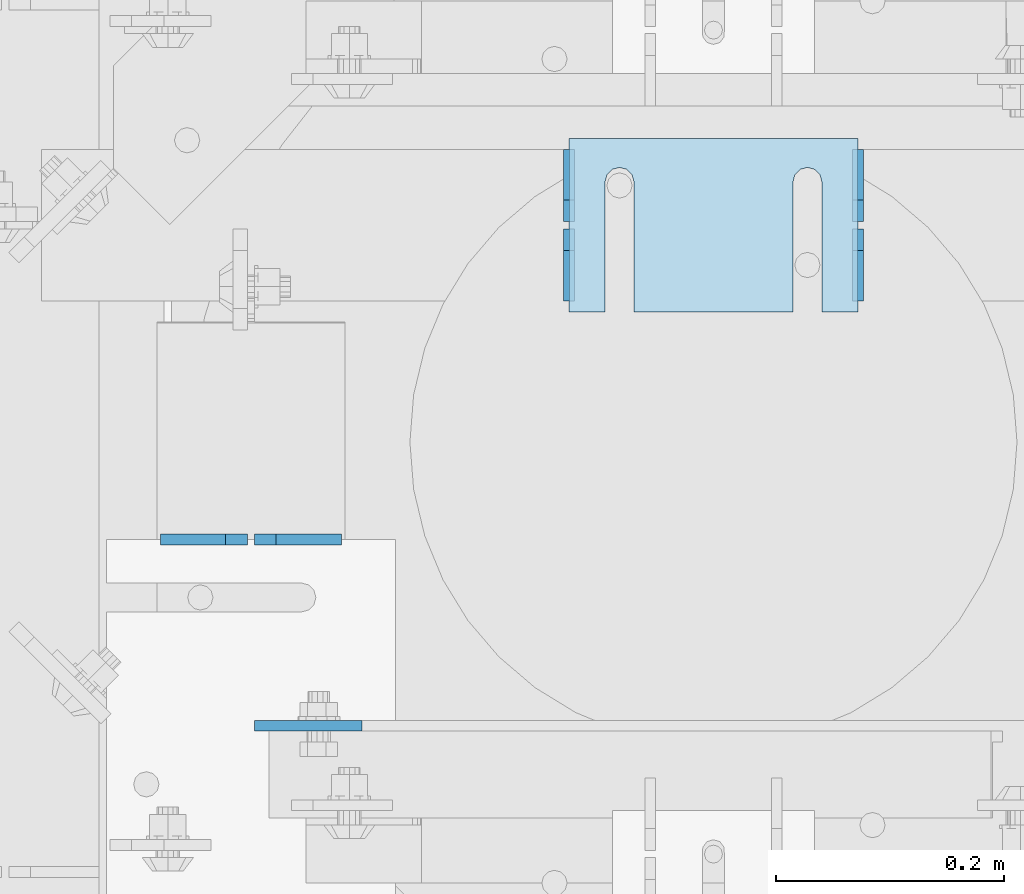
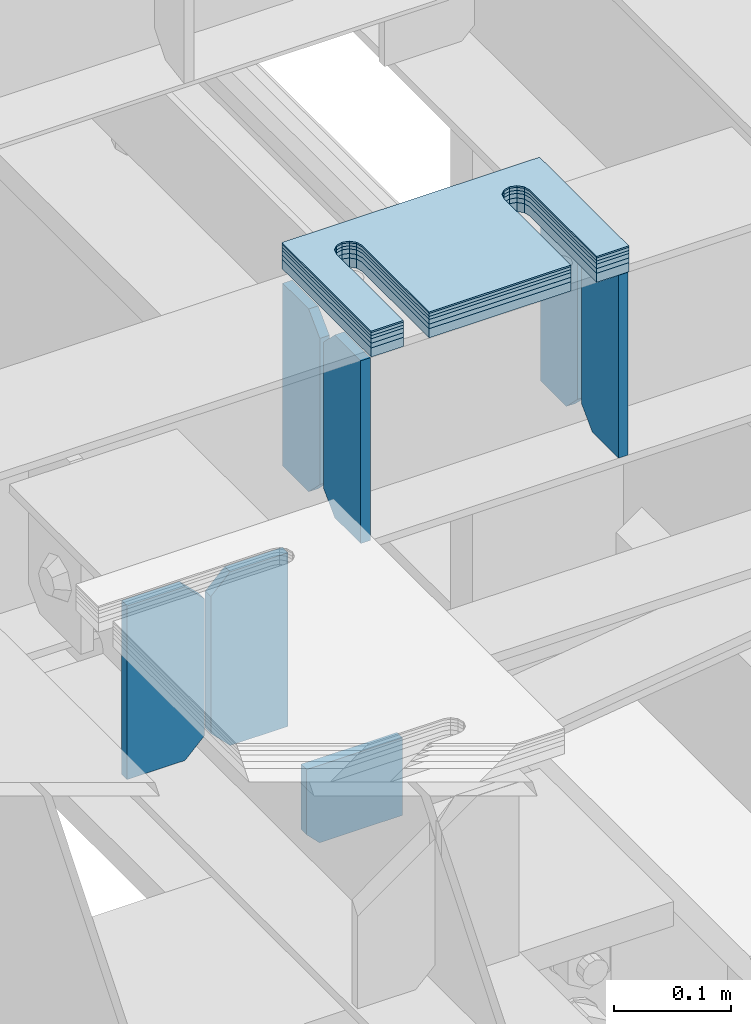
# One storey, part 1635 of 1876: 13 plates, 8 elements without a shape of their own.
"""IFC2X3 building model written with IfcOpenShell, lengths in millimetres."""

from ifc_helpers import new_model, si_unit, frame, origin_with_axes, place, context, subcontext, project, spatial, faceted_brep, material, type_object, element, aggregate, save


model = new_model("IFC2X3")

# Units and contexts
model_context = context("Model", 3, precision=1e-05, world=origin_with_axes())
body_context = subcontext(model_context, "Body", "Model", "MODEL_VIEW")
ifc_project = project(units=[si_unit("LENGTHUNIT", "METRE", prefix="MILLI"), si_unit("AREAUNIT", "SQUARE_METRE"), si_unit("VOLUMEUNIT", "CUBIC_METRE"), si_unit("MASSUNIT", "GRAM", prefix="KILO"), si_unit("TIMEUNIT", "SECOND"), si_unit("PLANEANGLEUNIT", "RADIAN"), si_unit("SOLIDANGLEUNIT", "STERADIAN"), si_unit("THERMODYNAMICTEMPERATUREUNIT", "DEGREE_CELSIUS"), si_unit("LUMINOUSINTENSITYUNIT", "LUMEN")], contexts=[model_context])

# Site, building, storey
site_placement = place(None, origin_with_axes())
site = spatial("IfcSite", under=ifc_project, at=site_placement, CompositionType="ELEMENT")
building_placement = place(site_placement, origin_with_axes())
building = spatial("IfcBuilding", under=site, at=building_placement, Name="Undefined", CompositionType="ELEMENT")
storey_placement = place(building_placement, origin_with_axes())
storey = spatial("IfcBuildingStorey", under=building, at=storey_placement, Name="Undefined", CompositionType="ELEMENT", Elevation=0.0)

# Assembly, plates
assembly_1_placement = place(storey_placement, origin_with_axes())
assembly_1 = element("IfcElementAssembly", 1, at=assembly_1_placement, inside=storey, Name="BEAM", AssemblyPlace="NOTDEFINED", PredefinedType="RIGID_FRAME")
ifc_material = material(Name="STEEL/A36")
plate_type_1 = type_object("IfcPlateType", PredefinedType="NOTDEFINED")
plate_1_placement = place(assembly_1_placement, frame((4092.57517785198, 2355.85161899327, 17792.7000000301), z_axis=(0.0, 0.0, 1.0), x_axis=(-1.0, 0.0, 0.0)))
plate_1 = element("IfcPlate", 2, at=plate_1_placement, type_object=plate_type_1, material=ifc_material, Name="PLATE", context=body_context, shape_type="Brep", body=[
    faceted_brep([(0.0, -4.76249999999982, 0.0), (0.0, -4.76249999999982, 180.975006103516), (0.0, 4.76249999999982, 180.975006103516), (0.0, 4.76249999999982, 0.0), (57.1499977111816, -4.76249999999982, 180.975006103516), (57.1499977111816, 4.76249999999982, 180.975006103516), (76.1999969482422, -4.76249999999982, 161.925006866455), (76.1999969482422, 4.76249999999982, 161.925006866455), (76.1999969482422, -4.76249999999982, 19.0499992370605), (76.1999969482422, 4.76249999999982, 19.0499992370605), (57.1499977111816, -4.76249999999982, 0.0), (57.1499977111816, 4.76249999999982, 0.0)], [[[0, 1, 2, 3]], [[1, 4, 5, 2]], [[4, 6, 7, 5]], [[6, 8, 9, 7]], [[8, 10, 11, 9]], [[10, 0, 3, 11]], [[5, 7, 9, 11, 3, 2]], [[10, 8, 6, 4, 1, 0]]]),
])
plate_2_placement = place(assembly_1_placement, frame((4010.02517785198, 2355.85161899327, 17792.7), z_axis=(0.0, 0.0, 1.0), x_axis=(-1.0, 0.0, 0.0)))
plate_2 = element("IfcPlate", 3, at=plate_2_placement, type_object=plate_type_1, material=ifc_material, Name="PLATE", context=body_context, shape_type="Brep", body=[
    faceted_brep([(0.0, -4.76249999999982, 19.0499992370605), (0.0, -4.76249999999982, 161.925006866455), (0.0, 4.76249999999982, 161.925006866455), (0.0, 4.76249999999982, 19.0499992370605), (19.0499992370605, -4.76249999999982, 180.975006103516), (19.0499992370605, 4.76249999999982, 180.975006103516), (76.1999969482422, -4.76249999999982, 180.975006103516), (76.1999969482422, 4.76249999999982, 180.975006103516), (76.1999969482422, -4.76250000000073, 0.0), (76.1999969482422, 4.76250000000073, 0.0), (19.0499992370605, -4.76249999999982, 0.0), (19.0499992370605, 4.76249999999982, 0.0)], [[[0, 1, 2, 3]], [[1, 4, 5, 2]], [[4, 6, 7, 5]], [[6, 8, 9, 7]], [[8, 10, 11, 9]], [[10, 0, 3, 11]], [[5, 7, 9, 11, 3, 2]], [[10, 8, 6, 4, 1, 0]]]),
])

assembly_2_placement = place(storey_placement, origin_with_axes())
assembly_2 = element("IfcElementAssembly", 4, at=assembly_2_placement, inside=storey, Name="BEAM", AssemblyPlace="NOTDEFINED", PredefinedType="RIGID_FRAME")
plate_type_2 = type_object("IfcPlateType", PredefinedType="NOTDEFINED")
plate_3_placement = place(assembly_2_placement, frame((4546.60015286048, 2565.3994140625, 17784.7625), z_axis=(0.0, 0.0, 1.0), x_axis=(0.0, 1.0, 0.0)))
plate_3 = element("IfcPlate", 5, at=plate_3_placement, type_object=plate_type_2, material=ifc_material, Name="PLATE", context=body_context, shape_type="Brep", body=[
    faceted_brep([(0.0, -4.76249999999982, 0.0), (0.0, -4.76249999999982, 190.5), (0.0, 4.76249999999982, 190.5), (0.0, 4.76249999999982, 0.0), (44.4500007629395, -4.76249999999982, 190.5), (44.4500007629395, 4.76249999999982, 190.5), (63.5, -4.76249999999982, 171.450000762939), (63.5, 4.76249999999982, 171.450000762939), (63.5, -4.76249999999982, 19.0499992370605), (63.5, 4.76249999999982, 19.0499992370605), (44.4500007629395, -4.76249999999982, 0.0), (44.4500007629395, 4.76249999999982, 0.0)], [[[0, 1, 2, 3]], [[1, 4, 5, 2]], [[4, 6, 7, 5]], [[6, 8, 9, 7]], [[8, 10, 11, 9]], [[10, 0, 3, 11]], [[5, 7, 9, 11, 3, 2]], [[10, 8, 6, 4, 1, 0]]]),
])
plate_4_placement = place(assembly_2_placement, frame((4546.60015286048, 2635.2494140625, 17784.7625), z_axis=(0.0, 0.0, 1.0), x_axis=(0.0, 1.0, 0.0)))
plate_4 = element("IfcPlate", 6, at=plate_4_placement, type_object=plate_type_2, material=ifc_material, Name="PLATE", context=body_context, shape_type="Brep", body=[
    faceted_brep([(0.0, -4.76249999999982, 19.0499992370605), (0.0, -4.76249999999982, 171.450000762939), (0.0, 4.76249999999982, 171.450000762939), (0.0, 4.76249999999982, 19.0499992370605), (19.0499992370605, -4.76249999999982, 190.5), (19.0499992370605, 4.76249999999982, 190.5), (63.5, -4.76249999999982, 190.5), (63.5, 4.76249999999982, 190.5), (63.5, -4.76249999999982, 0.0), (63.5, 4.76249999999982, 0.0), (19.0499992370605, -4.76249999999982, 0.0), (19.0499992370605, 4.76249999999982, 0.0)], [[[0, 1, 2, 3]], [[1, 4, 5, 2]], [[4, 6, 7, 5]], [[6, 8, 9, 7]], [[8, 10, 11, 9]], [[10, 0, 3, 11]], [[5, 7, 9, 11, 3, 2]], [[10, 8, 6, 4, 1, 0]]]),
])
plate_5_placement = place(assembly_2_placement, frame((4292.60061290776, 2565.3994140625, 17784.7625), z_axis=(0.0, 0.0, 1.0), x_axis=(0.0, 1.0, 0.0)))
plate_5 = element("IfcPlate", 7, at=plate_5_placement, type_object=plate_type_2, material=ifc_material, Name="PLATE", context=body_context, shape_type="Brep", body=[
    faceted_brep([(0.0, -4.76249999999982, 0.0), (0.0, -4.76249999999982, 190.5), (0.0, 4.76249999999982, 190.5), (0.0, 4.76249999999982, 0.0), (44.4500007629395, -4.76249999999982, 190.5), (44.4500007629395, 4.76249999999982, 190.5), (63.5, -4.76249999999982, 171.450000762939), (63.5, 4.76249999999982, 171.450000762939), (63.5, -4.76249999999982, 19.0499992370605), (63.5, 4.76249999999982, 19.0499992370605), (44.4500007629395, -4.76249999999982, 0.0), (44.4500007629395, 4.76249999999982, 0.0)], [[[0, 1, 2, 3]], [[1, 4, 5, 2]], [[4, 6, 7, 5]], [[6, 8, 9, 7]], [[8, 10, 11, 9]], [[10, 0, 3, 11]], [[5, 7, 9, 11, 3, 2]], [[10, 8, 6, 4, 1, 0]]]),
])
plate_6_placement = place(assembly_2_placement, frame((4292.60061290776, 2635.2494140625, 17784.7625), z_axis=(0.0, 0.0, 1.0), x_axis=(0.0, 1.0, 0.0)))
plate_6 = element("IfcPlate", 8, at=plate_6_placement, type_object=plate_type_2, material=ifc_material, Name="PLATE", context=body_context, shape_type="Brep", body=[
    faceted_brep([(0.0, -4.76249999999982, 19.0499992370605), (0.0, -4.76249999999982, 171.450000762939), (0.0, 4.76249999999982, 171.450000762939), (0.0, 4.76249999999982, 19.0499992370605), (19.0499992370605, -4.76249999999982, 190.5), (19.0499992370605, 4.76249999999982, 190.5), (63.5, -4.76249999999982, 190.5), (63.5, 4.76249999999982, 190.5), (63.5, -4.76249999999982, 0.0), (63.5, 4.76249999999982, 0.0), (19.0499992370605, -4.76249999999982, 0.0), (19.0499992370605, 4.76249999999982, 0.0)], [[[0, 1, 2, 3]], [[1, 4, 5, 2]], [[4, 6, 7, 5]], [[6, 8, 9, 7]], [[8, 10, 11, 9]], [[10, 0, 3, 11]], [[5, 7, 9, 11, 3, 2]], [[10, 8, 6, 4, 1, 0]]]),
])
aggregate(assembly_2, [plate_3, plate_4, plate_5, plate_6])

# Plate
plate_type_3 = type_object("IfcPlateType", PredefinedType="NOTDEFINED")
plate_7_placement = place(assembly_1_placement, frame((4016.37523571808, 2192.33995712735, 17792.7000000001), z_axis=(0.0, 0.0, 1.0), x_axis=(1.0, 0.0, 0.0)))
plate_7 = element("IfcPlate", 9, at=plate_7_placement, type_object=plate_type_3, material=ifc_material, Name="PLATE", context=body_context, shape_type="Brep", body=[
    faceted_brep([(3.7040990719106e-08, -4.76249999999982, 12.6999998092651), (2.3555503503303e-07, -4.76249999999982, 80.7660827636719), (2.35553216043627e-07, 4.76249999999982, 80.7660827636719), (3.70396264770534e-08, 4.76249999999982, 12.6999998092651), (94.5699691772488, -4.76249999998208, 80.7660827637555), (94.569969177247, 4.76250000001801, 80.7660827637555), (94.5699691772488, -4.76249999998208, 8.00355337560177e-11), (94.5699691772461, 4.76250000001801, 8.00355337560177e-11), (12.699999809267, -4.76249999999754, 1.09139364212751e-11), (12.6999998092651, 4.76250000000255, 1.09139364212751e-11)], [[[0, 1, 2, 3]], [[1, 4, 5, 2]], [[4, 6, 7, 5]], [[6, 8, 9, 7]], [[8, 0, 3, 9]], [[5, 7, 9, 3, 2]], [[8, 6, 4, 1, 0]]]),
])

aggregate(assembly_1, [plate_1, plate_2, plate_7])

# Assembly, plate
assembly_3_placement = place(storey_placement, origin_with_axes())
assembly_3 = element("IfcElementAssembly", 10, at=assembly_3_placement, inside=storey, Name="SHIM PLATE", AssemblyPlace="NOTDEFINED", PredefinedType="RIGID_FRAME")
plate_type_4 = type_object("IfcPlateType", PredefinedType="NOTDEFINED")
plate_8_placement = place(assembly_3_placement, frame((4546.60114192636, 2708.27516323207, 18009.3925), z_axis=(0.0, -1.0, 0.0), x_axis=(-1.0, 0.0, 0.0)))
plate_8 = element("IfcPlate", 11, at=plate_8_placement, type_object=plate_type_4, material=ifc_material, Name="SHIM PLATE", context=body_context, shape_type="Brep", body=[
    faceted_brep([(31.7473236467022, -0.793499999999767, 152.398895263674), (31.7495452849444, -0.793499999999767, 38.0994505459066), (31.7495452849444, 0.793499999999767, 38.0994505459066), (31.7473236467022, 0.793499999999767, 152.398895263674), (33.4510181364694, -0.793499999999767, 31.7494480392982), (33.4510181364694, 0.793499999999767, 31.7494480392982), (38.0995388011806, -0.793499999999767, 27.1009216783834), (38.0995388011806, 0.793499999999767, 27.1009216783834), (44.4495392228328, -0.793499999999767, 25.3994410457015), (44.4495392228328, 0.793499999999767, 25.3994410457015), (50.7995409628356, -0.793499999999767, 27.1009167582527), (50.7995409628356, 0.793499999999767, 27.1009167582527), (55.4480652293469, -0.793499999999767, 31.7494395173824), (55.4480652293469, 0.793499999999767, 31.7494395173824), (57.14954300102, -0.793499999999767, 38.0994407056476), (57.14954300102, 0.793499999999767, 38.0994407056476), (57.1473213626687, -0.793499999999767, 152.398894419415), (57.1473213626687, 0.793499999999767, 152.398895263676), (9.09494701772928e-13, -0.793499999999767, 0.0), (1.98268335225293e-05, -0.793499999999767, 152.398895263672), (1.98268335225293e-05, 0.793499999999767, 152.398895263672), (9.09494701772928e-13, 0.793499999999767, 0.0), (253.999542236328, -0.793499999999767, 6.16182660451159e-11), (253.999542236328, 0.793499999999767, 6.16182660451159e-11), (253.999557495107, -0.793499999999767, 152.398895263688), (253.999557495107, 0.793499999999767, 152.398895263688), (222.247321362667, 0.793499999999767, 152.398895263686), (222.247321362667, -0.793499999999767, 152.398895410166), (222.249543001019, 0.793499999999767, 38.0994416963979), (222.249543001019, -0.793499999999767, 38.0994416963979), (220.548065229345, 0.793499999999767, 31.7494405081325), (220.548065229345, -0.793499999999767, 31.7494405081325), (215.899540962834, 0.793499999999767, 27.100917749003), (215.899540962834, -0.793499999999767, 27.100917749003), (209.549539222831, 0.793499999999767, 25.3994420364518), (209.549539222831, -0.793499999999767, 25.3994420364518), (203.199538801179, 0.793499999999767, 27.1009226691335), (203.199538801179, -0.793499999999767, 27.1009226691335), (198.551018136468, 0.793499999999767, 31.7494490300483), (198.551018136468, -0.793499999999767, 31.7494490300483), (196.849545284943, 0.793499999999767, 38.0994515366567), (196.849545284943, -0.793499999999767, 38.0994515366567), (196.847323646701, -0.793499999999767, 152.398895263684), (196.847323646701, 0.793499999999767, 152.398895263684)], [[[0, 1, 2, 3]], [[4, 5, 2, 1]], [[6, 7, 5, 4]], [[8, 9, 7, 6]], [[10, 11, 9, 8]], [[12, 13, 11, 10]], [[14, 15, 13, 12]], [[16, 17, 15, 14]], [[18, 19, 20, 21]], [[22, 18, 21, 23]], [[24, 22, 23, 25]], [[24, 25, 26, 27]], [[27, 26, 28, 29]], [[29, 28, 30, 31]], [[31, 30, 32, 33]], [[33, 32, 34, 35]], [[35, 34, 36, 37]], [[37, 36, 38, 39]], [[39, 38, 40, 41]], [[42, 41, 40, 43]], [[12, 10, 8, 6, 4, 1, 0, 19, 18, 22, 24, 27, 29, 31, 33, 35, 37, 39, 41, 42, 16, 14]], [[20, 19, 0, 3]], [[43, 40, 38, 36, 34, 32, 30, 28, 26, 25, 23, 21, 20, 3, 2, 5, 7, 9, 11, 13, 15, 17]], [[42, 43, 17, 16]]]),
])
aggregate(assembly_3, [plate_8])

assembly_4_placement = place(storey_placement, origin_with_axes())
assembly_4 = element("IfcElementAssembly", 12, at=assembly_4_placement, inside=storey, Name="SHIM PLATE", AssemblyPlace="NOTDEFINED", PredefinedType="RIGID_FRAME")
plate_type_5 = type_object("IfcPlateType", PredefinedType="NOTDEFINED")
plate_9_placement = place(assembly_4_placement, frame((4546.60114192649, 2708.2751632316, 18007.0115), z_axis=(0.0, -1.0, 0.0), x_axis=(-1.0, 0.0, 0.0)))
plate_9 = element("IfcPlate", 13, at=plate_9_placement, type_object=plate_type_5, material=ifc_material, Name="SHIM PLATE", context=body_context, shape_type="Brep", body=[
    faceted_brep([(31.7473236467022, -1.58750000000146, 152.398895263674), (31.7495452849444, -1.58750000000146, 38.0994505459066), (31.7495452849444, 1.58750000000146, 38.0994505459066), (31.7473236467022, 1.58750000000146, 152.398895263674), (33.4510181364694, -1.58750000000146, 31.7494480392982), (33.4510181364694, 1.58750000000146, 31.7494480392982), (38.0995388011806, -1.58750000000146, 27.1009216783834), (38.0995388011806, 1.58750000000146, 27.1009216783834), (44.4495392228328, -1.58750000000146, 25.3994410457015), (44.4495392228328, 1.58750000000146, 25.3994410457015), (50.7995409628356, -1.58750000000146, 27.1009167582527), (50.7995409628356, 1.58750000000146, 27.1009167582527), (55.4480652293469, -1.58750000000146, 31.7494395173824), (55.4480652293469, 1.58750000000146, 31.7494395173824), (57.14954300102, -1.58750000000146, 38.0994407056476), (57.14954300102, 1.58750000000146, 38.0994407056476), (57.1473213626687, -1.58750000000146, 152.398894419415), (57.1473213626687, 1.58750000000146, 152.398895263676), (9.09494701772928e-13, -1.58750000000146, 4.54747350886464e-13), (1.98264133359771e-05, -1.58750000000146, 152.398895263672), (1.98264133359771e-05, 1.58750000000146, 152.398895263672), (9.09494701772928e-13, 1.58750000000146, 4.54747350886464e-13), (253.999542236328, -1.58750000000146, 6.16182660451159e-11), (253.999542236328, 1.58750000000146, 6.16182660451159e-11), (253.999557495107, -1.58750000000146, 152.398895263688), (253.999557495107, 1.58750000000146, 152.398895263688), (222.247321362667, 1.58750000000146, 152.398895263686), (222.247321362667, -1.58750000000146, 152.398895410166), (222.249543001019, 1.58750000000146, 38.0994416963979), (222.249543001019, -1.58750000000146, 38.0994416963979), (220.548065229345, 1.58750000000146, 31.7494405081325), (220.548065229345, -1.58750000000146, 31.7494405081325), (215.899540962834, 1.58750000000146, 27.100917749003), (215.899540962834, -1.58750000000146, 27.100917749003), (209.549539222831, 1.58750000000146, 25.3994420364518), (209.549539222831, -1.58750000000146, 25.3994420364518), (203.199538801179, 1.58750000000146, 27.1009226691335), (203.199538801179, -1.58750000000146, 27.1009226691335), (198.551018136468, 1.58750000000146, 31.7494490300483), (198.551018136468, -1.58750000000146, 31.7494490300483), (196.849545284943, 1.58750000000146, 38.0994515366567), (196.849545284943, -1.58750000000146, 38.0994515366567), (196.847323646701, -1.58750000000146, 152.398895263684), (196.847323646701, 1.58750000000146, 152.398895263684)], [[[0, 1, 2, 3]], [[4, 5, 2, 1]], [[6, 7, 5, 4]], [[8, 9, 7, 6]], [[10, 11, 9, 8]], [[12, 13, 11, 10]], [[14, 15, 13, 12]], [[16, 17, 15, 14]], [[18, 19, 20, 21]], [[22, 18, 21, 23]], [[24, 22, 23, 25]], [[24, 25, 26, 27]], [[27, 26, 28, 29]], [[29, 28, 30, 31]], [[31, 30, 32, 33]], [[33, 32, 34, 35]], [[35, 34, 36, 37]], [[37, 36, 38, 39]], [[39, 38, 40, 41]], [[42, 41, 40, 43]], [[12, 10, 8, 6, 4, 1, 0, 19, 18, 22, 24, 27, 29, 31, 33, 35, 37, 39, 41, 42, 16, 14]], [[20, 19, 0, 3]], [[43, 40, 38, 36, 34, 32, 30, 28, 26, 25, 23, 21, 20, 3, 2, 5, 7, 9, 11, 13, 15, 17]], [[42, 43, 17, 16]]]),
])
aggregate(assembly_4, [plate_9])

assembly_5_placement = place(storey_placement, origin_with_axes())
assembly_5 = element("IfcElementAssembly", 14, at=assembly_5_placement, inside=storey, Name="SHIM PLATE", AssemblyPlace="NOTDEFINED", PredefinedType="RIGID_FRAME")
plate_10_placement = place(assembly_5_placement, frame((4546.60114192663, 2708.27516323114, 18003.8365), z_axis=(0.0, -1.0, 0.0), x_axis=(-1.0, 0.0, 0.0)))
plate_10 = element("IfcPlate", 15, at=plate_10_placement, type_object=plate_type_5, material=ifc_material, Name="SHIM PLATE", context=body_context, shape_type="Brep", body=[
    faceted_brep([(31.7473236467022, -1.58750000000146, 152.398895263674), (31.7495452849444, -1.58750000000146, 38.0994505459066), (31.7495452849444, 1.58750000000146, 38.0994505459066), (31.7473236467022, 1.58750000000146, 152.398895263674), (33.4510181364694, -1.58750000000146, 31.7494480392982), (33.4510181364694, 1.58750000000146, 31.7494480392982), (38.0995388011806, -1.58750000000146, 27.1009216783834), (38.0995388011806, 1.58750000000146, 27.1009216783834), (44.4495392228328, -1.58750000000146, 25.3994410457015), (44.4495392228328, 1.58750000000146, 25.3994410457015), (50.7995409628356, -1.58750000000146, 27.1009167582527), (50.7995409628356, 1.58750000000146, 27.1009167582527), (55.4480652293469, -1.58750000000146, 31.7494395173824), (55.4480652293469, 1.58750000000146, 31.7494395173824), (57.14954300102, -1.58750000000146, 38.0994407056476), (57.14954300102, 1.58750000000146, 38.0994407056476), (57.1473213626687, -1.58750000000146, 152.398894419415), (57.1473213626687, 1.58750000000146, 152.398895263676), (9.09494701772928e-13, -1.58750000000146, 4.54747350886464e-13), (1.98264133359771e-05, -1.58750000000146, 152.398895263672), (1.98264133359771e-05, 1.58750000000146, 152.398895263672), (9.09494701772928e-13, 1.58750000000146, 4.54747350886464e-13), (253.999542236328, -1.58750000000146, 6.16182660451159e-11), (253.999542236328, 1.58750000000146, 6.16182660451159e-11), (253.999557495107, -1.58750000000146, 152.398895263688), (253.999557495107, 1.58750000000146, 152.398895263688), (222.247321362667, 1.58750000000146, 152.398895263686), (222.247321362667, -1.58750000000146, 152.398895410166), (222.249543001019, 1.58750000000146, 38.0994416963979), (222.249543001019, -1.58750000000146, 38.0994416963979), (220.548065229345, 1.58750000000146, 31.7494405081325), (220.548065229345, -1.58750000000146, 31.7494405081325), (215.899540962834, 1.58750000000146, 27.100917749003), (215.899540962834, -1.58750000000146, 27.100917749003), (209.549539222831, 1.58750000000146, 25.3994420364518), (209.549539222831, -1.58750000000146, 25.3994420364518), (203.199538801179, 1.58750000000146, 27.1009226691335), (203.199538801179, -1.58750000000146, 27.1009226691335), (198.551018136468, 1.58750000000146, 31.7494490300483), (198.551018136468, -1.58750000000146, 31.7494490300483), (196.849545284943, 1.58750000000146, 38.0994515366567), (196.849545284943, -1.58750000000146, 38.0994515366567), (196.847323646701, -1.58750000000146, 152.398895263684), (196.847323646701, 1.58750000000146, 152.398895263684)], [[[0, 1, 2, 3]], [[4, 5, 2, 1]], [[6, 7, 5, 4]], [[8, 9, 7, 6]], [[10, 11, 9, 8]], [[12, 13, 11, 10]], [[14, 15, 13, 12]], [[16, 17, 15, 14]], [[18, 19, 20, 21]], [[22, 18, 21, 23]], [[24, 22, 23, 25]], [[24, 25, 26, 27]], [[27, 26, 28, 29]], [[29, 28, 30, 31]], [[31, 30, 32, 33]], [[33, 32, 34, 35]], [[35, 34, 36, 37]], [[37, 36, 38, 39]], [[39, 38, 40, 41]], [[42, 41, 40, 43]], [[12, 10, 8, 6, 4, 1, 0, 19, 18, 22, 24, 27, 29, 31, 33, 35, 37, 39, 41, 42, 16, 14]], [[20, 19, 0, 3]], [[43, 40, 38, 36, 34, 32, 30, 28, 26, 25, 23, 21, 20, 3, 2, 5, 7, 9, 11, 13, 15, 17]], [[42, 43, 17, 16]]]),
])
aggregate(assembly_5, [plate_10])

assembly_6_placement = place(storey_placement, origin_with_axes())
assembly_6 = element("IfcElementAssembly", 16, at=assembly_6_placement, inside=storey, Name="SHIM PLATE", AssemblyPlace="NOTDEFINED", PredefinedType="RIGID_FRAME")
plate_type_6 = type_object("IfcPlateType", PredefinedType="NOTDEFINED")
plate_11_placement = place(assembly_6_placement, frame((4546.60114192677, 2708.27516323068, 17999.868), z_axis=(0.0, -1.0, 0.0), x_axis=(-1.0, 0.0, 0.0)))
plate_11 = element("IfcPlate", 17, at=plate_11_placement, type_object=plate_type_6, material=ifc_material, Name="SHIM PLATE", context=body_context, shape_type="Brep", body=[
    faceted_brep([(31.7473236467022, -2.38100000000122, 152.398895263674), (31.7495452849444, -2.38100000000122, 38.0994505459066), (31.7495452849444, 2.38100000000122, 38.0994505459066), (31.7473236467022, 2.38100000000122, 152.398895263674), (33.4510181364694, -2.38100000000122, 31.7494480392982), (33.4510181364694, 2.38100000000122, 31.7494480392982), (38.0995388011806, -2.38100000000122, 27.1009216783834), (38.0995388011806, 2.38100000000122, 27.1009216783834), (44.4495392228328, -2.38100000000122, 25.3994410457015), (44.4495392228328, 2.38100000000122, 25.3994410457015), (50.7995409628356, -2.38100000000122, 27.1009167582527), (50.7995409628356, 2.38100000000122, 27.1009167582527), (55.4480652293469, -2.38100000000122, 31.7494395173824), (55.4480652293469, 2.38100000000122, 31.7494395173824), (57.14954300102, -2.38100000000122, 38.0994407056476), (57.14954300102, 2.38100000000122, 38.0994407056476), (57.1473213626687, -2.38100000000122, 152.398894419415), (57.1473213626687, 2.38100000000122, 152.398895263676), (0.0, -2.38100000000122, 4.54747350886464e-13), (1.98259931494249e-05, -2.38100000000122, 152.398895263672), (1.98259931494249e-05, 2.38100000000122, 152.398895263672), (0.0, 2.38100000000122, 4.54747350886464e-13), (253.999542236328, -2.38100000000122, 6.16182660451159e-11), (253.999542236328, 2.38100000000122, 6.16182660451159e-11), (253.999557495107, -2.38100000000122, 152.398895263688), (253.999557495107, 2.38100000000122, 152.398895263688), (222.247321362667, 2.38100000000122, 152.398895263686), (222.247321362667, -2.38100000000122, 152.398895410166), (222.249543001019, 2.38100000000122, 38.0994416963979), (222.249543001019, -2.38100000000122, 38.0994416963979), (220.548065229345, 2.38100000000122, 31.7494405081325), (220.548065229345, -2.38100000000122, 31.7494405081325), (215.899540962834, 2.38100000000122, 27.100917749003), (215.899540962834, -2.38100000000122, 27.100917749003), (209.549539222831, 2.38100000000122, 25.3994420364518), (209.549539222831, -2.38100000000122, 25.3994420364518), (203.199538801179, 2.38100000000122, 27.1009226691335), (203.199538801179, -2.38100000000122, 27.1009226691335), (198.551018136468, 2.38100000000122, 31.7494490300483), (198.551018136468, -2.38100000000122, 31.7494490300483), (196.849545284943, 2.38100000000122, 38.0994515366567), (196.849545284943, -2.38100000000122, 38.0994515366567), (196.847323646701, -2.38100000000122, 152.398895263684), (196.847323646701, 2.38100000000122, 152.398895263684)], [[[0, 1, 2, 3]], [[4, 5, 2, 1]], [[6, 7, 5, 4]], [[8, 9, 7, 6]], [[10, 11, 9, 8]], [[12, 13, 11, 10]], [[14, 15, 13, 12]], [[16, 17, 15, 14]], [[18, 19, 20, 21]], [[22, 18, 21, 23]], [[24, 22, 23, 25]], [[24, 25, 26, 27]], [[27, 26, 28, 29]], [[29, 28, 30, 31]], [[31, 30, 32, 33]], [[33, 32, 34, 35]], [[35, 34, 36, 37]], [[37, 36, 38, 39]], [[39, 38, 40, 41]], [[42, 41, 40, 43]], [[12, 10, 8, 6, 4, 1, 0, 19, 18, 22, 24, 27, 29, 31, 33, 35, 37, 39, 41, 42, 16, 14]], [[20, 19, 0, 3]], [[43, 40, 38, 36, 34, 32, 30, 28, 26, 25, 23, 21, 20, 3, 2, 5, 7, 9, 11, 13, 15, 17]], [[42, 43, 17, 16]]]),
])
aggregate(assembly_6, [plate_11])

assembly_7_placement = place(storey_placement, origin_with_axes())
assembly_7 = element("IfcElementAssembly", 18, at=assembly_7_placement, inside=storey, Name="SHIM PLATE", AssemblyPlace="NOTDEFINED", PredefinedType="RIGID_FRAME")
plate_12_placement = place(assembly_7_placement, frame((4546.6011419269, 2708.27516323022, 17995.106), z_axis=(0.0, -1.0, 0.0), x_axis=(-1.0, 0.0, 0.0)))
plate_12 = element("IfcPlate", 19, at=plate_12_placement, type_object=plate_type_6, material=ifc_material, Name="SHIM PLATE", context=body_context, shape_type="Brep", body=[
    faceted_brep([(31.7473236467022, -2.38100000000122, 152.398895263674), (31.7495452849444, -2.38100000000122, 38.0994505459066), (31.7495452849444, 2.38100000000122, 38.0994505459066), (31.7473236467022, 2.38100000000122, 152.398895263674), (33.4510181364694, -2.38100000000122, 31.7494480392982), (33.4510181364694, 2.38100000000122, 31.7494480392982), (38.0995388011806, -2.38100000000122, 27.1009216783834), (38.0995388011806, 2.38100000000122, 27.1009216783834), (44.4495392228328, -2.38100000000122, 25.3994410457015), (44.4495392228328, 2.38100000000122, 25.3994410457015), (50.7995409628356, -2.38100000000122, 27.1009167582527), (50.7995409628356, 2.38100000000122, 27.1009167582527), (55.4480652293469, -2.38100000000122, 31.7494395173824), (55.4480652293469, 2.38100000000122, 31.7494395173824), (57.14954300102, -2.38100000000122, 38.0994407056476), (57.14954300102, 2.38100000000122, 38.0994407056476), (57.1473213626687, -2.38100000000122, 152.398894419415), (57.1473213626687, 2.38100000000122, 152.398895263676), (0.0, -2.38100000000122, 4.54747350886464e-13), (1.98259931494249e-05, -2.38100000000122, 152.398895263672), (1.98259931494249e-05, 2.38100000000122, 152.398895263672), (0.0, 2.38100000000122, 4.54747350886464e-13), (253.999542236328, -2.38100000000122, 6.16182660451159e-11), (253.999542236328, 2.38100000000122, 6.16182660451159e-11), (253.999557495107, -2.38100000000122, 152.398895263688), (253.999557495107, 2.38100000000122, 152.398895263688), (222.247321362667, 2.38100000000122, 152.398895263686), (222.247321362667, -2.38100000000122, 152.398895410166), (222.249543001019, 2.38100000000122, 38.0994416963979), (222.249543001019, -2.38100000000122, 38.0994416963979), (220.548065229345, 2.38100000000122, 31.7494405081325), (220.548065229345, -2.38100000000122, 31.7494405081325), (215.899540962834, 2.38100000000122, 27.100917749003), (215.899540962834, -2.38100000000122, 27.100917749003), (209.549539222831, 2.38100000000122, 25.3994420364518), (209.549539222831, -2.38100000000122, 25.3994420364518), (203.199538801179, 2.38100000000122, 27.1009226691335), (203.199538801179, -2.38100000000122, 27.1009226691335), (198.551018136468, 2.38100000000122, 31.7494490300483), (198.551018136468, -2.38100000000122, 31.7494490300483), (196.849545284943, 2.38100000000122, 38.0994515366567), (196.849545284943, -2.38100000000122, 38.0994515366567), (196.847323646701, -2.38100000000122, 152.398895263684), (196.847323646701, 2.38100000000122, 152.398895263684)], [[[0, 1, 2, 3]], [[4, 5, 2, 1]], [[6, 7, 5, 4]], [[8, 9, 7, 6]], [[10, 11, 9, 8]], [[12, 13, 11, 10]], [[14, 15, 13, 12]], [[16, 17, 15, 14]], [[18, 19, 20, 21]], [[22, 18, 21, 23]], [[24, 22, 23, 25]], [[24, 25, 26, 27]], [[27, 26, 28, 29]], [[29, 28, 30, 31]], [[31, 30, 32, 33]], [[33, 32, 34, 35]], [[35, 34, 36, 37]], [[37, 36, 38, 39]], [[39, 38, 40, 41]], [[42, 41, 40, 43]], [[12, 10, 8, 6, 4, 1, 0, 19, 18, 22, 24, 27, 29, 31, 33, 35, 37, 39, 41, 42, 16, 14]], [[20, 19, 0, 3]], [[43, 40, 38, 36, 34, 32, 30, 28, 26, 25, 23, 21, 20, 3, 2, 5, 7, 9, 11, 13, 15, 17]], [[42, 43, 17, 16]]]),
])
aggregate(assembly_7, [plate_12])

assembly_8_placement = place(storey_placement, origin_with_axes())
assembly_8 = element("IfcElementAssembly", 20, at=assembly_8_placement, inside=storey, Name="SHIM PLATE", AssemblyPlace="NOTDEFINED", PredefinedType="RIGID_FRAME")
plate_type_7 = type_object("IfcPlateType", PredefinedType="NOTDEFINED")
plate_13_placement = place(assembly_8_placement, frame((4546.60114192704, 2708.27516322975, 17987.9625), z_axis=(0.0, -1.0, 0.0), x_axis=(-1.0, 0.0, 0.0)))
plate_13 = element("IfcPlate", 21, at=plate_13_placement, type_object=plate_type_7, material=ifc_material, Name="SHIM PLATE", context=body_context, shape_type="Brep", body=[
    faceted_brep([(31.7473236467022, -4.76250000000073, 152.398895263674), (31.7495452849444, -4.76250000000073, 38.0994505459066), (31.7495452849444, 4.76250000000073, 38.0994505459066), (31.7473236467022, 4.76250000000073, 152.398895263674), (33.4510181364694, -4.76250000000073, 31.7494480392982), (33.4510181364694, 4.76250000000073, 31.7494480392982), (38.0995388011806, -4.76250000000073, 27.1009216783834), (38.0995388011806, 4.76250000000073, 27.1009216783834), (44.4495392228328, -4.76250000000073, 25.3994410457015), (44.4495392228328, 4.76250000000073, 25.3994410457015), (50.7995409628356, -4.76250000000073, 27.1009167582527), (50.7995409628356, 4.76250000000073, 27.1009167582527), (55.4480652293469, -4.76250000000073, 31.7494395173824), (55.4480652293469, 4.76250000000073, 31.7494395173824), (57.14954300102, -4.76250000000073, 38.0994407056476), (57.14954300102, 4.76250000000073, 38.0994407056476), (57.1473213626687, -4.76250000000073, 152.398894419415), (57.1473213626687, 4.76250000000073, 152.398895263676), (0.0, -4.76249999999982, 0.0), (1.98255729628727e-05, -4.76250000000073, 152.398895263672), (1.98255729628727e-05, 4.76250000000073, 152.398895263672), (0.0, 4.76249999999982, 0.0), (253.999542236328, -4.76250000000073, 6.16182660451159e-11), (253.999542236328, 4.76250000000073, 6.16182660451159e-11), (253.999557495107, -4.76250000000073, 152.398895263688), (253.999557495107, 4.76250000000073, 152.398895263688), (222.247321362667, 4.76250000000073, 152.398895263686), (222.247321362667, -4.76250000000073, 152.398895410166), (222.249543001019, 4.76250000000073, 38.0994416963979), (222.249543001019, -4.76250000000073, 38.0994416963979), (220.548065229345, 4.76250000000073, 31.7494405081325), (220.548065229345, -4.76250000000073, 31.7494405081325), (215.899540962834, 4.76250000000073, 27.100917749003), (215.899540962834, -4.76250000000073, 27.100917749003), (209.549539222831, 4.76250000000073, 25.3994420364518), (209.549539222831, -4.76250000000073, 25.3994420364518), (203.199538801179, 4.76250000000073, 27.1009226691335), (203.199538801179, -4.76250000000073, 27.1009226691335), (198.551018136468, 4.76250000000073, 31.7494490300483), (198.551018136468, -4.76250000000073, 31.7494490300483), (196.849545284943, 4.76250000000073, 38.0994515366567), (196.849545284943, -4.76250000000073, 38.0994515366567), (196.847323646701, -4.76250000000073, 152.398895263684), (196.847323646701, 4.76250000000073, 152.398895263684)], [[[0, 1, 2, 3]], [[4, 5, 2, 1]], [[6, 7, 5, 4]], [[8, 9, 7, 6]], [[10, 11, 9, 8]], [[12, 13, 11, 10]], [[14, 15, 13, 12]], [[16, 17, 15, 14]], [[18, 19, 20, 21]], [[22, 18, 21, 23]], [[24, 22, 23, 25]], [[24, 25, 26, 27]], [[27, 26, 28, 29]], [[29, 28, 30, 31]], [[31, 30, 32, 33]], [[33, 32, 34, 35]], [[35, 34, 36, 37]], [[37, 36, 38, 39]], [[39, 38, 40, 41]], [[42, 41, 40, 43]], [[12, 10, 8, 6, 4, 1, 0, 19, 18, 22, 24, 27, 29, 31, 33, 35, 37, 39, 41, 42, 16, 14]], [[20, 19, 0, 3]], [[43, 40, 38, 36, 34, 32, 30, 28, 26, 25, 23, 21, 20, 3, 2, 5, 7, 9, 11, 13, 15, 17]], [[42, 43, 17, 16]]]),
])
aggregate(assembly_8, [plate_13])

save(model, "model.ifc")
